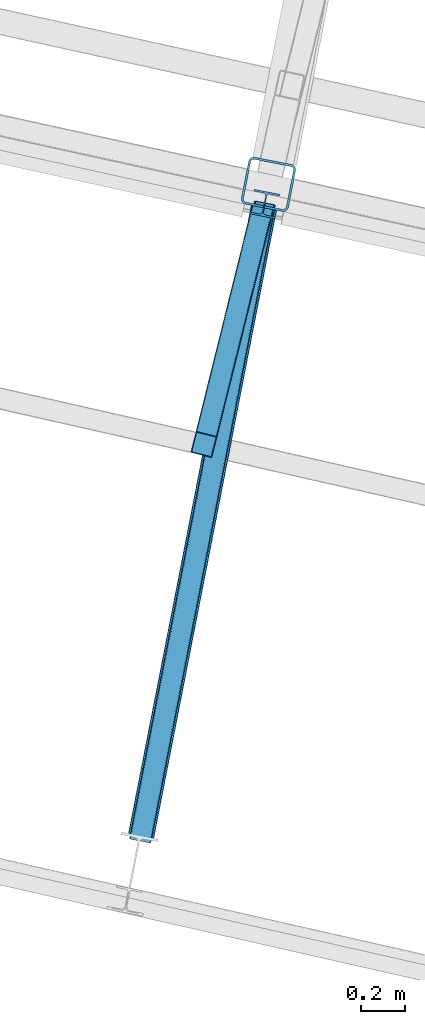
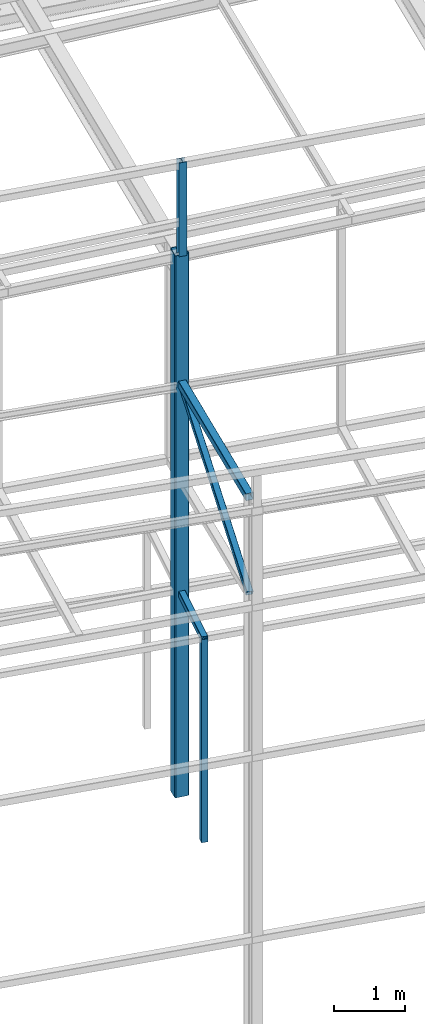
# One storey, part 24 of 215: 5 beams, 1 member, 6 elements without a shape of their own.
"""IFC2X3 building model written with IfcOpenShell, lengths in millimetres."""

from ifc_helpers import new_model, si_unit, frame, origin_with_axes, origin_2d_with_axis, place, context, subcontext, project, spatial, hollow_rectangle, i_section, extrude, clip, halfspace, material, type_object, element, aggregate, save


model = new_model("IFC2X3")

# Units and contexts
model_context = context("Model", 3, precision=1e-05, world=origin_with_axes())
body_context = subcontext(model_context, "Body", "Model", "MODEL_VIEW")
ifc_project = project(units=[si_unit("LENGTHUNIT", "METRE", prefix="MILLI"), si_unit("AREAUNIT", "SQUARE_METRE"), si_unit("VOLUMEUNIT", "CUBIC_METRE"), si_unit("MASSUNIT", "GRAM", prefix="KILO"), si_unit("TIMEUNIT", "SECOND"), si_unit("PLANEANGLEUNIT", "RADIAN"), si_unit("SOLIDANGLEUNIT", "STERADIAN"), si_unit("THERMODYNAMICTEMPERATUREUNIT", "DEGREE_CELSIUS"), si_unit("LUMINOUSINTENSITYUNIT", "LUMEN")], contexts=[model_context])

# Site, building, storey
site_placement = place(None, origin_with_axes())
site = spatial("IfcSite", under=ifc_project, at=site_placement, CompositionType="ELEMENT")
building_placement = place(site_placement, origin_with_axes())
building = spatial("IfcBuilding", under=site, at=building_placement, Name="Undefined", CompositionType="ELEMENT")
storey_placement = place(building_placement, origin_with_axes())
storey = spatial("IfcBuildingStorey", under=building, at=storey_placement, Name="Undefined", CompositionType="ELEMENT", Elevation=0.0)

# Assembly, beam
assembly_1_placement = place(storey_placement, origin_with_axes())
assembly_1 = element("IfcElementAssembly", 1, at=assembly_1_placement, inside=storey, Name="Steel Assembly", AssemblyPlace="NOTDEFINED", PredefinedType="RIGID_FRAME")
ifc_material = material(Name="STEEL/S275JR")
beam_type_1 = type_object("IfcBeamType", PredefinedType="NOTDEFINED")
beam_1_placement = place(assembly_1_placement, frame((54691.4165887681, 6816.39401989562, 6760.00000147429), z_axis=(-0.970514446045369, 0.241042963011268, 0.0), x_axis=(0.0, 0.0, -1.0)))
beam_1 = element("IfcBeam", 2, at=beam_1_placement, type_object=beam_type_1, material=ifc_material, Name="MONTANT", context=body_context, shape_type="SweptSolid", body=[
    extrude(hollow_rectangle(XDim=100.0, YDim=100.0, WallThickness=4.0, InnerFilletRadius=4.0, OuterFilletRadius=8.0, at=origin_2d_with_axis()), frame((3499.99999998675, 0.0, 0.0), z_axis=(-1.0, 0.0, 0.0), x_axis=(-6.93889390390723e-18, -1.0, -3.46944695195361e-18)), (0.0, 0.0, 1.0), 3500.0),
])
aggregate(assembly_1, [beam_1])

assembly_2_placement = place(storey_placement, origin_with_axes())
assembly_2 = element("IfcElementAssembly", 3, at=assembly_2_placement, inside=storey, Name="Steel Assembly", AssemblyPlace="NOTDEFINED", PredefinedType="RIGID_FRAME")
beam_2_placement = place(assembly_2_placement, frame((54679.3643613888, 6767.86830751072, 6760.00000147687), z_axis=(-0.970514446045369, 0.241042963011268, 0.0), x_axis=(0.241043332093801, 0.970514354377676, 0.0)))
beam_2 = element("IfcBeam", 4, at=beam_2_placement, type_object=beam_type_1, material=ifc_material, Name="POUTRE", context=body_context, shape_type="Clipping", body=[
    clip(extrude(hollow_rectangle(XDim=100.0, YDim=100.0, WallThickness=4.0, InnerFilletRadius=4.0, OuterFilletRadius=8.0, at=origin_2d_with_axis()), frame((1213.45293164893, 9.09494701772928e-13, 7.30963769878381e-12), z_axis=(-1.0, 0.0, 0.0), x_axis=(-6.93889390390723e-18, -1.0, -3.46944695195361e-18)), (0.0, 0.0, 1.0), 1213.5), halfspace(frame((1165.59223278983, -49.9999999999991, 56.641633110863), z_axis=(-0.998730980059548, 0.0, -0.0503629771686942), x_axis=(-6.93889390390723e-18, -1.0, -3.46944695195361e-18)), True)),
])
aggregate(assembly_2, [beam_2])

assembly_3_placement = place(storey_placement, origin_with_axes())
assembly_3 = element("IfcElementAssembly", 5, at=assembly_3_placement, inside=storey, Name="Steel Assembly", AssemblyPlace="NOTDEFINED", PredefinedType="RIGID_FRAME")
beam_type_2 = type_object("IfcBeamType", PredefinedType="NOTDEFINED")
beam_3_placement = place(assembly_3_placement, frame((54403.7036431302, 5022.14563575269, 10373.171659004), z_axis=(-0.981422412140383, 0.191859451027444, 0.0), x_axis=(0.191859470081235, 0.981422408415534, 0.0)))
beam_3 = element("IfcBeam", 6, at=beam_3_placement, type_object=beam_type_2, material=ifc_material, context=body_context, shape_type="SweptSolid", body=[
    extrude(hollow_rectangle(XDim=120.0, YDim=120.0, WallThickness=5.0, InnerFilletRadius=5.0, OuterFilletRadius=10.0, at=origin_2d_with_axis()), frame((2933.14518294702, 5.62751907443717e-16, 6.0656020728427e-22), z_axis=(-1.0, 0.0, 0.0), x_axis=(-6.93889390390723e-18, -1.0, -3.46944695195361e-18)), (0.0, 0.0, 1.0), 2933.1),
])
aggregate(assembly_3, [beam_3])

# Assembly, member
assembly_4_placement = place(storey_placement, origin_with_axes())
assembly_4 = element("IfcElementAssembly", 7, at=assembly_4_placement, inside=storey, Name="Steel Assembly", AssemblyPlace="NOTDEFINED", PredefinedType="RIGID_FRAME")
member_type = type_object("IfcMemberType", PredefinedType="NOTDEFINED")
member_placement = place(assembly_4_placement, frame((54966.4552691556, 7900.80005367256, 10373.1456557591), z_axis=(-0.981360632095246, 0.192174373018651, -0.000565799000054881), x_axis=(-0.166896924945231, -0.853730629719842, -0.493243781838138)))
member = element("IfcMember", 8, at=member_placement, type_object=member_type, material=ifc_material, context=body_context, shape_type="SweptSolid", body=[
    extrude(hollow_rectangle(XDim=100.0, YDim=100.0, WallThickness=5.0, InnerFilletRadius=5.0, OuterFilletRadius=10.0, at=origin_2d_with_axis()), frame((3371.85320723908, -5.42249222497229e-13, -7.31671945606781e-12), z_axis=(-1.0, 0.0, 0.0), x_axis=(-6.93889390390723e-18, -1.0, -3.46944695195361e-18)), (0.0, 0.0, 1.0), 3371.9),
])
aggregate(assembly_4, [member])

# Assembly, beam
assembly_5_placement = place(storey_placement, origin_with_axes())
assembly_5 = element("IfcElementAssembly", 9, at=assembly_5_placement, inside=storey, Name="Steel Assembly", AssemblyPlace="NOTDEFINED", PredefinedType="RIGID_FRAME")
beam_type_3 = type_object("IfcBeamType", Name="HEA120", PredefinedType="NOTDEFINED")
beam_4_placement = place(assembly_5_placement, frame((54969.9346607005, 7918.60008506968, 14219.9969927395), z_axis=(0.191859470081235, 0.981422408415534, 0.0), x_axis=(0.0, 0.0, -1.0)))
beam_4 = element("IfcBeam", 10, at=beam_4_placement, type_object=beam_type_3, material=ifc_material, ObjectType="HEA120", context=body_context, shape_type="SweptSolid", body=[
    extrude(i_section(OverallWidth=120.0, OverallDepth=114.0, WebThickness=5.0, FlangeThickness=8.0, FilletRadius=12.0, at=origin_2d_with_axis()), frame((1617.65767331747, 7.27595761418343e-12, 0.0), z_axis=(-1.0, 0.0, 0.0), x_axis=(-6.93889390390723e-18, -1.0, -3.46944695195361e-18)), (0.0, 0.0, 1.0), 1617.7),
])
aggregate(assembly_5, [beam_4])

assembly_6_placement = place(storey_placement, origin_with_axes())
assembly_6 = element("IfcElementAssembly", 11, at=assembly_6_placement, inside=storey, Name="Steel Assembly", AssemblyPlace="NOTDEFINED", PredefinedType="RIGID_FRAME")
beam_type_4 = type_object("IfcBeamType", PredefinedType="NOTDEFINED")
beam_5_placement = place(assembly_6_placement, frame((54987.559463137, 8008.75658982675, 12602.3393193318), z_axis=(0.191859470081235, 0.981422408415534, 0.0), x_axis=(0.0, 0.0, -1.0)))
beam_5 = element("IfcBeam", 12, at=beam_5_placement, type_object=beam_type_4, material=ifc_material, Name="POTEAU", context=body_context, shape_type="SweptSolid", body=[
    extrude(hollow_rectangle(XDim=220.0, YDim=220.0, WallThickness=10.0, InnerFilletRadius=15.0, OuterFilletRadius=25.0, at=origin_2d_with_axis()), frame((9342.34140944662, 0.0, 0.0), z_axis=(-1.0, 0.0, 0.0), x_axis=(-6.93889390390723e-18, -1.0, -3.46944695195361e-18)), (0.0, 0.0, 1.0), 9342.3),
])
aggregate(assembly_6, [beam_5])

save(model, "model.ifc")
